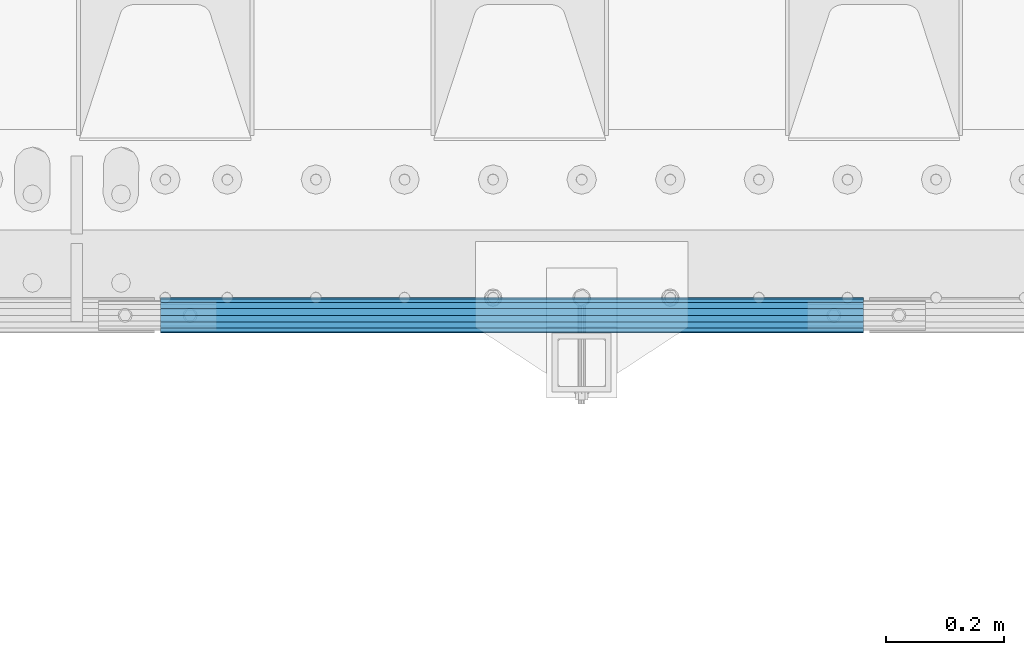
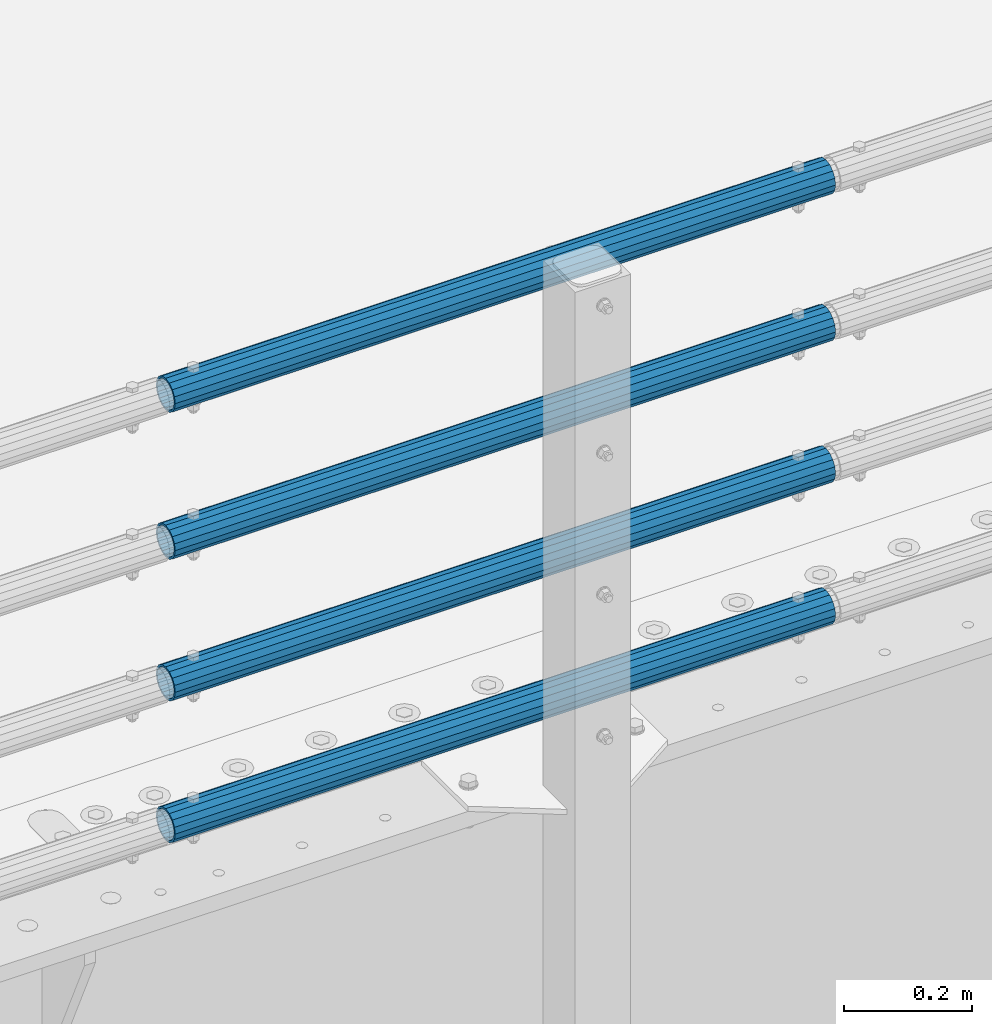
# One storey, part 107 of 240: 4 beams.
"""IFC2X3 building model written with IfcOpenShell, lengths in millimetres."""

from ifc_helpers import new_model, si_unit, frame, origin_with_axes, place, context, subcontext, project, spatial, faceted_brep, material, type_object, element, save


model = new_model("IFC2X3")

# Units and contexts
model_context = context("Model", 3, precision=1e-05, world=origin_with_axes())
body_context = subcontext(model_context, "Body", "Model", "MODEL_VIEW")
ifc_project = project(units=[si_unit("LENGTHUNIT", "METRE", prefix="MILLI"), si_unit("AREAUNIT", "SQUARE_METRE"), si_unit("VOLUMEUNIT", "CUBIC_METRE"), si_unit("MASSUNIT", "GRAM", prefix="KILO"), si_unit("TIMEUNIT", "SECOND"), si_unit("PLANEANGLEUNIT", "RADIAN"), si_unit("SOLIDANGLEUNIT", "STERADIAN"), si_unit("THERMODYNAMICTEMPERATUREUNIT", "DEGREE_CELSIUS"), si_unit("LUMINOUSINTENSITYUNIT", "LUMEN")], contexts=[model_context])

# Site, building, storey
site_placement = place(None, origin_with_axes())
site = spatial("IfcSite", under=ifc_project, at=site_placement, CompositionType="ELEMENT")
building_placement = place(site_placement, origin_with_axes())
building = spatial("IfcBuilding", under=site, at=building_placement, Name="Standard", CompositionType="ELEMENT")
storey_placement = place(building_placement, origin_with_axes())
storey = spatial("IfcBuildingStorey", under=building, at=storey_placement, Name="Undefined", CompositionType="ELEMENT", Elevation=0.0)

# Beams
ifc_material = material()
beam_type = type_object("IfcBeamType", PredefinedType="NOTDEFINED")
beam_1_placement = place(storey_placement, frame((53792.0000000001, 23870.1499999996, 419.849999999748), z_axis=(0.0, -1.0, 0.0), x_axis=(1.0, 0.0, 0.0)))
element("IfcBeam", 1, at=beam_1_placement, inside=storey, type_object=beam_type, material=ifc_material, context=body_context, shape_type="Brep", body=[
    faceted_brep([(0.0, -26.5500000000029, 0.0), (0.0, -24.5290015881765, 10.1602451292931), (1190.0, -24.5290015881747, 10.1602451292929), (1190.0, -26.55, 0.0), (0.0, -18.7736850405054, 18.7736850405028), (1190.0, -18.7736850405028, 18.7736850405054), (0.0, -10.1602451292929, 24.5290015881747), (1190.0, -10.1602451292931, 24.5290015881765), (0.0, 0.0, 26.55), (1190.0, 0.0, 26.5500000000029), (0.0, 10.1602451292929, 24.5290015881747), (1190.0, 10.1602451292932, 24.5290015881765), (0.0, 18.7736850405054, 18.7736850405028), (1190.0, 18.7736850405029, 18.7736850405054), (0.0, 24.5290015881765, 10.1602451292931), (1190.0, 24.5290015881747, 10.1602451292929), (0.0, 26.5500000000029, 0.0), (1190.0, 26.55, 0.0), (0.0, 24.5290015881765, -10.1602451292931), (1190.0, 24.5290015881747, -10.1602451292929), (0.0, 18.7736850405054, -18.7736850405028), (1190.0, 18.7736850405028, -18.7736850405054), (0.0, 10.1602451292929, -24.5290015881747), (1190.0, 10.1602451292931, -24.5290015881765), (0.0, 0.0, -26.55), (1190.0, 0.0, -26.5500000000029), (0.0, -10.1602451292929, -24.5290015881747), (1190.0, -10.1602451292931, -24.5290015881765), (0.0, -18.7736850405054, -18.7736850405028), (1190.0, -18.7736850405028, -18.7736850405054), (0.0, -24.5290015881765, -10.1602451292931), (1190.0, -24.5290015881747, -10.1602451292929), (0.0, -30.1500000000015, 0.0), (0.0, -27.8549679052157, -11.5379054858058), (1190.0, -27.8549679052153, -11.5379054858058), (1190.0, -30.15, 0.0), (0.0, -21.3192694527752, -21.3192694527752), (1190.0, -21.3192694527744, -21.3192694527752), (0.0, -11.5379054858058, -27.8549679052157), (1190.0, -11.5379054858075, -27.8549679052157), (0.0, 0.0, -30.1500000000015), (1190.0, 0.0, -30.1500000000015), (0.0, 11.5379054858058, -27.8549679052157), (1190.0, 11.5379054858075, -27.8549679052157), (0.0, 21.3192694527752, -21.3192694527752), (1190.0, 21.3192694527744, -21.3192694527752), (0.0, 27.8549679052157, -11.5379054858058), (1190.0, 27.8549679052153, -11.5379054858058), (0.0, 30.1500000000015, 0.0), (1190.0, 30.15, 0.0), (0.0, 27.8549679052157, 11.5379054858058), (1190.0, 27.8549679052153, 11.5379054858058), (0.0, 21.3192694527752, 21.3192694527752), (1190.0, 21.3192694527744, 21.3192694527752), (0.0, 11.5379054858058, 27.8549679052157), (1190.0, 11.5379054858075, 27.8549679052157), (0.0, 0.0, 30.1500000000015), (1190.0, 0.0, 30.1500000000015), (0.0, -11.5379054858058, 27.8549679052157), (1190.0, -11.5379054858075, 27.8549679052157), (0.0, -21.3192694527752, 21.3192694527752), (1190.0, -21.3192694527744, 21.3192694527752), (0.0, -27.8549679052157, 11.5379054858058), (1190.0, -27.8549679052153, 11.5379054858058)], [[[0, 1, 2, 3]], [[1, 4, 5, 2]], [[4, 6, 7, 5]], [[6, 8, 9, 7]], [[8, 10, 11, 9]], [[10, 12, 13, 11]], [[12, 14, 15, 13]], [[14, 16, 17, 15]], [[16, 18, 19, 17]], [[18, 20, 21, 19]], [[20, 22, 23, 21]], [[22, 24, 25, 23]], [[24, 26, 27, 25]], [[26, 28, 29, 27]], [[28, 30, 31, 29]], [[30, 0, 3, 31]], [[32, 33, 34, 35]], [[33, 36, 37, 34]], [[36, 38, 39, 37]], [[38, 40, 41, 39]], [[40, 42, 43, 41]], [[42, 44, 45, 43]], [[44, 46, 47, 45]], [[46, 48, 49, 47]], [[48, 50, 51, 49]], [[50, 52, 53, 51]], [[52, 54, 55, 53]], [[54, 56, 57, 55]], [[56, 58, 59, 57]], [[58, 60, 61, 59]], [[60, 62, 63, 61]], [[62, 32, 35, 63]], [[37, 39, 41, 43, 45, 47, 49, 51, 53, 55, 57, 59, 61, 63, 35, 34], [5, 7, 9, 11, 13, 15, 17, 19, 21, 23, 25, 27, 29, 31, 3, 2]], [[62, 60, 58, 56, 54, 52, 50, 48, 46, 44, 42, 40, 38, 36, 33, 32], [30, 28, 26, 24, 22, 20, 18, 16, 14, 12, 10, 8, 6, 4, 1, 0]]]),
])
beam_2_placement = place(storey_placement, frame((53792.0000000001, 23870.1499999996, 149.549999999748), z_axis=(0.0, -1.0, 0.0), x_axis=(1.0, 0.0, 0.0)))
element("IfcBeam", 2, at=beam_2_placement, inside=storey, type_object=beam_type, material=ifc_material, context=body_context, shape_type="Brep", body=[
    faceted_brep([(0.0, -26.5500000000029, 0.0), (0.0, -24.5290015881765, 10.1602451292931), (1190.0, -24.5290015881747, 10.1602451292929), (1190.0, -26.55, 0.0), (0.0, -18.7736850405054, 18.7736850405028), (1190.0, -18.7736850405028, 18.7736850405054), (0.0, -10.1602451292929, 24.5290015881747), (1190.0, -10.1602451292931, 24.5290015881765), (0.0, 0.0, 26.55), (1190.0, 0.0, 26.5500000000029), (0.0, 10.1602451292929, 24.5290015881747), (1190.0, 10.1602451292932, 24.5290015881765), (0.0, 18.7736850405054, 18.7736850405028), (1190.0, 18.7736850405029, 18.7736850405054), (0.0, 24.5290015881765, 10.1602451292931), (1190.0, 24.5290015881747, 10.1602451292929), (0.0, 26.5500000000029, 0.0), (1190.0, 26.55, 0.0), (0.0, 24.5290015881765, -10.1602451292931), (1190.0, 24.5290015881747, -10.1602451292929), (0.0, 18.7736850405054, -18.7736850405028), (1190.0, 18.7736850405028, -18.7736850405054), (0.0, 10.1602451292929, -24.5290015881747), (1190.0, 10.1602451292931, -24.5290015881765), (0.0, 0.0, -26.55), (1190.0, 0.0, -26.5500000000029), (0.0, -10.1602451292929, -24.5290015881747), (1190.0, -10.1602451292931, -24.5290015881765), (0.0, -18.7736850405054, -18.7736850405028), (1190.0, -18.7736850405028, -18.7736850405054), (0.0, -24.5290015881765, -10.1602451292931), (1190.0, -24.5290015881747, -10.1602451292929), (0.0, -30.1500000000015, 0.0), (0.0, -27.8549679052157, -11.5379054858058), (1190.0, -27.8549679052153, -11.5379054858058), (1190.0, -30.15, 0.0), (0.0, -21.3192694527752, -21.3192694527752), (1190.0, -21.3192694527744, -21.3192694527752), (0.0, -11.5379054858058, -27.8549679052157), (1190.0, -11.5379054858075, -27.8549679052157), (0.0, 0.0, -30.1500000000015), (1190.0, 0.0, -30.1500000000015), (0.0, 11.5379054858058, -27.8549679052157), (1190.0, 11.5379054858075, -27.8549679052157), (0.0, 21.3192694527752, -21.3192694527752), (1190.0, 21.3192694527744, -21.3192694527752), (0.0, 27.8549679052157, -11.5379054858058), (1190.0, 27.8549679052153, -11.5379054858058), (0.0, 30.1500000000015, 0.0), (1190.0, 30.15, 0.0), (0.0, 27.8549679052157, 11.5379054858058), (1190.0, 27.8549679052153, 11.5379054858058), (0.0, 21.3192694527752, 21.3192694527752), (1190.0, 21.3192694527744, 21.3192694527752), (0.0, 11.5379054858058, 27.8549679052157), (1190.0, 11.5379054858075, 27.8549679052157), (0.0, 0.0, 30.1500000000015), (1190.0, 0.0, 30.1500000000015), (0.0, -11.5379054858058, 27.8549679052157), (1190.0, -11.5379054858075, 27.8549679052157), (0.0, -21.3192694527752, 21.3192694527752), (1190.0, -21.3192694527744, 21.3192694527752), (0.0, -27.8549679052157, 11.5379054858058), (1190.0, -27.8549679052153, 11.5379054858058)], [[[0, 1, 2, 3]], [[1, 4, 5, 2]], [[4, 6, 7, 5]], [[6, 8, 9, 7]], [[8, 10, 11, 9]], [[10, 12, 13, 11]], [[12, 14, 15, 13]], [[14, 16, 17, 15]], [[16, 18, 19, 17]], [[18, 20, 21, 19]], [[20, 22, 23, 21]], [[22, 24, 25, 23]], [[24, 26, 27, 25]], [[26, 28, 29, 27]], [[28, 30, 31, 29]], [[30, 0, 3, 31]], [[32, 33, 34, 35]], [[33, 36, 37, 34]], [[36, 38, 39, 37]], [[38, 40, 41, 39]], [[40, 42, 43, 41]], [[42, 44, 45, 43]], [[44, 46, 47, 45]], [[46, 48, 49, 47]], [[48, 50, 51, 49]], [[50, 52, 53, 51]], [[52, 54, 55, 53]], [[54, 56, 57, 55]], [[56, 58, 59, 57]], [[58, 60, 61, 59]], [[60, 62, 63, 61]], [[62, 32, 35, 63]], [[37, 39, 41, 43, 45, 47, 49, 51, 53, 55, 57, 59, 61, 63, 35, 34], [5, 7, 9, 11, 13, 15, 17, 19, 21, 23, 25, 27, 29, 31, 3, 2]], [[62, 60, 58, 56, 54, 52, 50, 48, 46, 44, 42, 40, 38, 36, 33, 32], [30, 28, 26, 24, 22, 20, 18, 16, 14, 12, 10, 8, 6, 4, 1, 0]]]),
])
beam_3_placement = place(storey_placement, frame((53792.0000000001, 23870.1499999996, 969.549999999748), z_axis=(0.0, -1.0, 0.0), x_axis=(1.0, 0.0, 0.0)))
element("IfcBeam", 3, at=beam_3_placement, inside=storey, type_object=beam_type, material=ifc_material, context=body_context, shape_type="Brep", body=[
    faceted_brep([(0.0, -26.5500000000029, 0.0), (0.0, -24.5290015881765, 10.1602451292931), (1190.0, -24.5290015881747, 10.1602451292929), (1190.0, -26.55, 0.0), (0.0, -18.7736850405054, 18.7736850405028), (1190.0, -18.7736850405028, 18.7736850405054), (0.0, -10.1602451292929, 24.5290015881747), (1190.0, -10.1602451292931, 24.5290015881765), (0.0, 0.0, 26.55), (1190.0, 0.0, 26.5500000000029), (0.0, 10.1602451292929, 24.5290015881747), (1190.0, 10.1602451292932, 24.5290015881765), (0.0, 18.7736850405054, 18.7736850405028), (1190.0, 18.7736850405029, 18.7736850405054), (0.0, 24.5290015881765, 10.1602451292931), (1190.0, 24.5290015881747, 10.1602451292929), (0.0, 26.5500000000029, 0.0), (1190.0, 26.55, 0.0), (0.0, 24.5290015881765, -10.1602451292931), (1190.0, 24.5290015881747, -10.1602451292929), (0.0, 18.7736850405054, -18.7736850405028), (1190.0, 18.7736850405028, -18.7736850405054), (0.0, 10.1602451292929, -24.5290015881747), (1190.0, 10.1602451292931, -24.5290015881765), (0.0, 0.0, -26.55), (1190.0, 0.0, -26.5500000000029), (0.0, -10.1602451292929, -24.5290015881747), (1190.0, -10.1602451292931, -24.5290015881765), (0.0, -18.7736850405054, -18.7736850405028), (1190.0, -18.7736850405028, -18.7736850405054), (0.0, -24.5290015881765, -10.1602451292931), (1190.0, -24.5290015881747, -10.1602451292929), (0.0, -30.1500000000015, 0.0), (0.0, -27.8549679052157, -11.5379054858058), (1190.0, -27.8549679052153, -11.5379054858058), (1190.0, -30.15, 0.0), (0.0, -21.3192694527752, -21.3192694527752), (1190.0, -21.3192694527744, -21.3192694527752), (0.0, -11.5379054858058, -27.8549679052157), (1190.0, -11.5379054858075, -27.8549679052157), (0.0, 0.0, -30.1500000000015), (1190.0, 0.0, -30.1500000000015), (0.0, 11.5379054858058, -27.8549679052157), (1190.0, 11.5379054858075, -27.8549679052157), (0.0, 21.3192694527752, -21.3192694527752), (1190.0, 21.3192694527744, -21.3192694527752), (0.0, 27.8549679052157, -11.5379054858058), (1190.0, 27.8549679052153, -11.5379054858058), (0.0, 30.1500000000015, 0.0), (1190.0, 30.15, 0.0), (0.0, 27.8549679052157, 11.5379054858058), (1190.0, 27.8549679052153, 11.5379054858058), (0.0, 21.3192694527752, 21.3192694527752), (1190.0, 21.3192694527744, 21.3192694527752), (0.0, 11.5379054858058, 27.8549679052157), (1190.0, 11.5379054858075, 27.8549679052157), (0.0, 0.0, 30.1500000000015), (1190.0, 0.0, 30.1500000000015), (0.0, -11.5379054858058, 27.8549679052157), (1190.0, -11.5379054858075, 27.8549679052157), (0.0, -21.3192694527752, 21.3192694527752), (1190.0, -21.3192694527744, 21.3192694527752), (0.0, -27.8549679052157, 11.5379054858058), (1190.0, -27.8549679052153, 11.5379054858058)], [[[0, 1, 2, 3]], [[1, 4, 5, 2]], [[4, 6, 7, 5]], [[6, 8, 9, 7]], [[8, 10, 11, 9]], [[10, 12, 13, 11]], [[12, 14, 15, 13]], [[14, 16, 17, 15]], [[16, 18, 19, 17]], [[18, 20, 21, 19]], [[20, 22, 23, 21]], [[22, 24, 25, 23]], [[24, 26, 27, 25]], [[26, 28, 29, 27]], [[28, 30, 31, 29]], [[30, 0, 3, 31]], [[32, 33, 34, 35]], [[33, 36, 37, 34]], [[36, 38, 39, 37]], [[38, 40, 41, 39]], [[40, 42, 43, 41]], [[42, 44, 45, 43]], [[44, 46, 47, 45]], [[46, 48, 49, 47]], [[48, 50, 51, 49]], [[50, 52, 53, 51]], [[52, 54, 55, 53]], [[54, 56, 57, 55]], [[56, 58, 59, 57]], [[58, 60, 61, 59]], [[60, 62, 63, 61]], [[62, 32, 35, 63]], [[37, 39, 41, 43, 45, 47, 49, 51, 53, 55, 57, 59, 61, 63, 35, 34], [5, 7, 9, 11, 13, 15, 17, 19, 21, 23, 25, 27, 29, 31, 3, 2]], [[62, 60, 58, 56, 54, 52, 50, 48, 46, 44, 42, 40, 38, 36, 33, 32], [30, 28, 26, 24, 22, 20, 18, 16, 14, 12, 10, 8, 6, 4, 1, 0]]]),
])
beam_4_placement = place(storey_placement, frame((53792.0000000001, 23870.1499999996, 689.549999999748), z_axis=(0.0, -1.0, 0.0), x_axis=(1.0, 0.0, 0.0)))
element("IfcBeam", 4, at=beam_4_placement, inside=storey, type_object=beam_type, material=ifc_material, context=body_context, shape_type="Brep", body=[
    faceted_brep([(0.0, -26.5500000000029, 0.0), (0.0, -24.5290015881765, 10.1602451292931), (1190.0, -24.5290015881747, 10.1602451292929), (1190.0, -26.55, 0.0), (0.0, -18.7736850405054, 18.7736850405028), (1190.0, -18.7736850405028, 18.7736850405054), (0.0, -10.1602451292929, 24.5290015881747), (1190.0, -10.1602451292931, 24.5290015881765), (0.0, 0.0, 26.55), (1190.0, 0.0, 26.5500000000029), (0.0, 10.1602451292929, 24.5290015881747), (1190.0, 10.1602451292932, 24.5290015881765), (0.0, 18.7736850405054, 18.7736850405028), (1190.0, 18.7736850405029, 18.7736850405054), (0.0, 24.5290015881765, 10.1602451292931), (1190.0, 24.5290015881747, 10.1602451292929), (0.0, 26.5500000000029, 0.0), (1190.0, 26.55, 0.0), (0.0, 24.5290015881765, -10.1602451292931), (1190.0, 24.5290015881747, -10.1602451292929), (0.0, 18.7736850405054, -18.7736850405028), (1190.0, 18.7736850405028, -18.7736850405054), (0.0, 10.1602451292929, -24.5290015881747), (1190.0, 10.1602451292931, -24.5290015881765), (0.0, 0.0, -26.55), (1190.0, 0.0, -26.5500000000029), (0.0, -10.1602451292929, -24.5290015881747), (1190.0, -10.1602451292931, -24.5290015881765), (0.0, -18.7736850405054, -18.7736850405028), (1190.0, -18.7736850405028, -18.7736850405054), (0.0, -24.5290015881765, -10.1602451292931), (1190.0, -24.5290015881747, -10.1602451292929), (0.0, -30.1500000000015, 0.0), (0.0, -27.8549679052157, -11.5379054858058), (1190.0, -27.8549679052153, -11.5379054858058), (1190.0, -30.15, 0.0), (0.0, -21.3192694527752, -21.3192694527752), (1190.0, -21.3192694527744, -21.3192694527752), (0.0, -11.5379054858058, -27.8549679052157), (1190.0, -11.5379054858075, -27.8549679052157), (0.0, 0.0, -30.1500000000015), (1190.0, 0.0, -30.1500000000015), (0.0, 11.5379054858058, -27.8549679052157), (1190.0, 11.5379054858075, -27.8549679052157), (0.0, 21.3192694527752, -21.3192694527752), (1190.0, 21.3192694527744, -21.3192694527752), (0.0, 27.8549679052157, -11.5379054858058), (1190.0, 27.8549679052153, -11.5379054858058), (0.0, 30.1500000000015, 0.0), (1190.0, 30.15, 0.0), (0.0, 27.8549679052157, 11.5379054858058), (1190.0, 27.8549679052153, 11.5379054858058), (0.0, 21.3192694527752, 21.3192694527752), (1190.0, 21.3192694527744, 21.3192694527752), (0.0, 11.5379054858058, 27.8549679052157), (1190.0, 11.5379054858075, 27.8549679052157), (0.0, 0.0, 30.1500000000015), (1190.0, 0.0, 30.1500000000015), (0.0, -11.5379054858058, 27.8549679052157), (1190.0, -11.5379054858075, 27.8549679052157), (0.0, -21.3192694527752, 21.3192694527752), (1190.0, -21.3192694527744, 21.3192694527752), (0.0, -27.8549679052157, 11.5379054858058), (1190.0, -27.8549679052153, 11.5379054858058)], [[[0, 1, 2, 3]], [[1, 4, 5, 2]], [[4, 6, 7, 5]], [[6, 8, 9, 7]], [[8, 10, 11, 9]], [[10, 12, 13, 11]], [[12, 14, 15, 13]], [[14, 16, 17, 15]], [[16, 18, 19, 17]], [[18, 20, 21, 19]], [[20, 22, 23, 21]], [[22, 24, 25, 23]], [[24, 26, 27, 25]], [[26, 28, 29, 27]], [[28, 30, 31, 29]], [[30, 0, 3, 31]], [[32, 33, 34, 35]], [[33, 36, 37, 34]], [[36, 38, 39, 37]], [[38, 40, 41, 39]], [[40, 42, 43, 41]], [[42, 44, 45, 43]], [[44, 46, 47, 45]], [[46, 48, 49, 47]], [[48, 50, 51, 49]], [[50, 52, 53, 51]], [[52, 54, 55, 53]], [[54, 56, 57, 55]], [[56, 58, 59, 57]], [[58, 60, 61, 59]], [[60, 62, 63, 61]], [[62, 32, 35, 63]], [[37, 39, 41, 43, 45, 47, 49, 51, 53, 55, 57, 59, 61, 63, 35, 34], [5, 7, 9, 11, 13, 15, 17, 19, 21, 23, 25, 27, 29, 31, 3, 2]], [[62, 60, 58, 56, 54, 52, 50, 48, 46, 44, 42, 40, 38, 36, 33, 32], [30, 28, 26, 24, 22, 20, 18, 16, 14, 12, 10, 8, 6, 4, 1, 0]]]),
])

save(model, "model.ifc")
